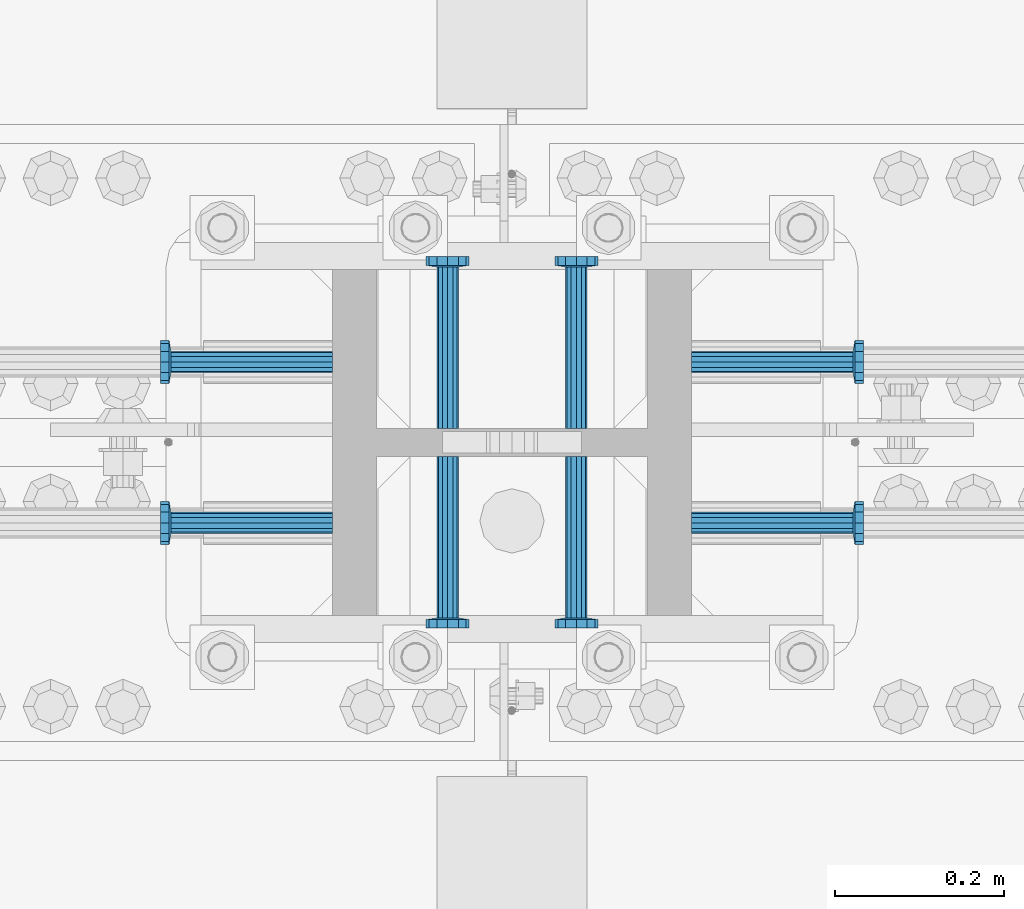
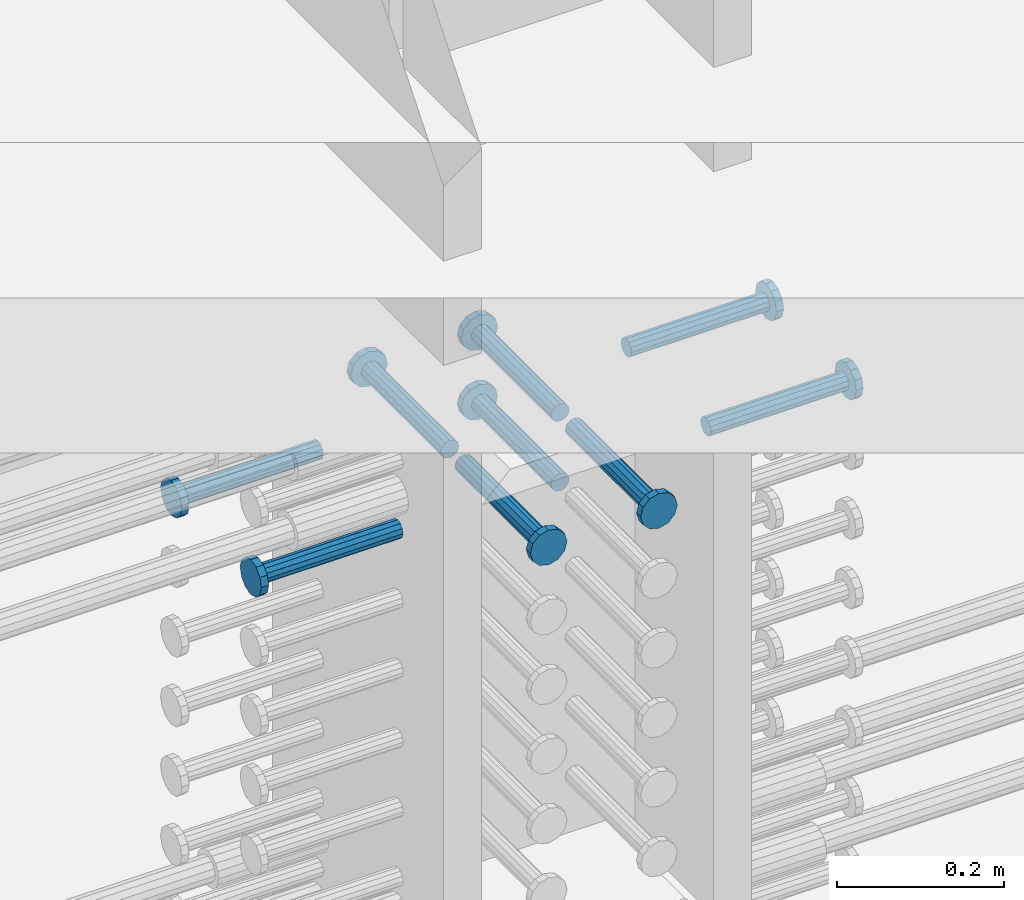
# One storey, part 1217 of 1763: 9 beams, 1 element without a shape of its own.
"""IFC2X3 building model written with IfcOpenShell, lengths in millimetres."""

from ifc_helpers import new_model, si_unit, frame, origin_with_axes, place, context, subcontext, project, spatial, faceted_brep, material, type_object, element, aggregate, save


model = new_model("IFC2X3")

# Units and contexts
model_context = context("Model", 3, precision=1e-05, world=origin_with_axes())
body_context = subcontext(model_context, "Body", "Model", "MODEL_VIEW")
ifc_project = project(units=[si_unit("LENGTHUNIT", "METRE", prefix="MILLI"), si_unit("AREAUNIT", "SQUARE_METRE"), si_unit("VOLUMEUNIT", "CUBIC_METRE"), si_unit("MASSUNIT", "GRAM", prefix="KILO"), si_unit("TIMEUNIT", "SECOND"), si_unit("PLANEANGLEUNIT", "RADIAN"), si_unit("SOLIDANGLEUNIT", "STERADIAN"), si_unit("THERMODYNAMICTEMPERATUREUNIT", "DEGREE_CELSIUS"), si_unit("LUMINOUSINTENSITYUNIT", "LUMEN")], contexts=[model_context])

# Site, building, storey
site_placement = place(None, origin_with_axes())
site = spatial("IfcSite", under=ifc_project, at=site_placement, CompositionType="ELEMENT")
building_placement = place(site_placement, origin_with_axes())
building = spatial("IfcBuilding", under=site, at=building_placement, Name="Undefined", CompositionType="ELEMENT")
storey_placement = place(building_placement, origin_with_axes())
storey = spatial("IfcBuildingStorey", under=building, at=storey_placement, Name="Undefined", CompositionType="ELEMENT", Elevation=0.0)

# Assembly, beams
assembly_placement = place(storey_placement, origin_with_axes())
assembly = element("IfcElementAssembly", 1, at=assembly_placement, inside=storey, Name="COLUMN", AssemblyPlace="NOTDEFINED", PredefinedType="RIGID_FRAME")
ifc_material = material(Name="STEEL/A108")
beam_type = type_object("IfcBeamType", PredefinedType="NOTDEFINED")
beam_1_placement = place(assembly_placement, frame((-61518.2373431004, 473.869000000006, 4724.40000000007), z_axis=(1.0, 0.0, 0.0), x_axis=(0.0, 1.0, 0.0)))
beam_1 = element("IfcBeam", 2, at=beam_1_placement, type_object=beam_type, material=ifc_material, Name="HEADED STUD ANCHOR", context=body_context, shape_type="Brep", body=[
    faceted_brep([(0.0, -12.6999999999971, -1.81898940354586e-12), (3.63797880709171e-12, -11.0, -6.34999990463257), (191.00799999576, -11.0, -6.34999990454889), (191.007999995752, -12.6999998092651, 8.36735125631094e-11), (7.27595761418343e-12, -6.34999990463257, -11.0), (191.00799999576, -6.34999990463257, -10.9999999999163), (3.63797880709171e-12, 0.0, -12.6999998092651), (191.00799999576, 0.0, -12.6999998091815), (7.27595761418343e-12, 6.34999990463257, -11.0), (191.00799999576, 6.34999990463257, -10.9999999999163), (3.63797880709171e-12, 11.0, -6.34999990463257), (191.00799999576, 11.0, -6.34999990454889), (0.0, 12.6999999999971, -1.81898940354586e-12), (191.007999995752, 12.6999998092651, 8.36735125631094e-11), (0.0, 11.0, 6.34999990463257), (191.007999995752, 11.0, 6.34999990471624), (-3.63797880709171e-12, 6.34999990463257, 11.0), (191.007999995749, 6.34999990463257, 11.0000000000837), (-3.63797880709171e-12, 0.0, 12.6999998092651), (191.007999995749, 0.0, 12.6999998093488), (-3.63797880709171e-12, -6.34999990463257, 11.0), (191.007999995749, -6.34999990463257, 11.0000000000837), (0.0, -11.0, 6.34999990463257), (191.007999995752, -11.0, 6.34999990471624), (193.039999995715, -22.0, -12.6999998091796), (193.039999995708, -25.3999996185303, 8.54925019666553e-11), (193.039999995719, -12.6999998092651, -21.9999999999145), (193.039999995719, 0.0, -25.3999996184448), (193.039999995719, 12.6999998092651, -21.9999999999145), (193.039999995715, 22.0, -12.6999998091796), (193.039999995708, 25.3999996185303, 8.54925019666553e-11), (193.039999995704, 22.0, 12.6999998093506), (193.039999995701, 12.6999998092651, 22.0000000000855), (193.039999995697, 0.0, 25.3999996186158), (193.039999995701, -12.6999998092651, 22.0000000000855), (193.039999995704, -22.0, 12.6999998093506), (203.199999995486, -22.0, -12.6999998091742), (203.199999995482, -25.3999996185303, 9.09494701772928e-11), (203.199999995493, -12.6999998092651, -21.9999999999091), (203.199999995493, 0.0, -25.3999996184393), (203.199999995493, 12.6999998092651, -21.9999999999091), (203.199999995486, 22.0, -12.6999998091742), (203.199999995482, 25.3999996185303, 9.09494701772928e-11), (203.199999995479, 22.0, 12.6999998093561), (203.199999995475, 12.6999998092651, 22.0000000000909), (203.199999995471, 0.0, 25.3999996186212), (203.199999995475, -12.6999998092651, 22.0000000000909), (203.199999995479, -22.0, 12.6999998093561)], [[[0, 1, 2, 3]], [[1, 4, 5, 2]], [[4, 6, 7, 5]], [[6, 8, 9, 7]], [[8, 10, 11, 9]], [[10, 12, 13, 11]], [[12, 14, 15, 13]], [[14, 16, 17, 15]], [[16, 18, 19, 17]], [[18, 20, 21, 19]], [[20, 22, 23, 21]], [[22, 0, 3, 23]], [[22, 20, 18, 16, 14, 12, 10, 8, 6, 4, 1, 0]], [[3, 2, 24, 25]], [[2, 5, 26, 24]], [[5, 7, 27, 26]], [[7, 9, 28, 27]], [[9, 11, 29, 28]], [[11, 13, 30, 29]], [[13, 15, 31, 30]], [[15, 17, 32, 31]], [[17, 19, 33, 32]], [[19, 21, 34, 33]], [[21, 23, 35, 34]], [[23, 3, 25, 35]], [[25, 24, 36, 37]], [[24, 26, 38, 36]], [[26, 27, 39, 38]], [[27, 28, 40, 39]], [[28, 29, 41, 40]], [[29, 30, 42, 41]], [[30, 31, 43, 42]], [[31, 32, 44, 43]], [[32, 33, 45, 44]], [[33, 34, 46, 45]], [[34, 35, 47, 46]], [[35, 25, 37, 47]], [[38, 39, 40, 41, 42, 43, 44, 45, 46, 47, 37, 36]]]),
])
beam_2_placement = place(assembly_placement, frame((-61670.6373431002, 473.868999002865, 4724.40000000007), z_axis=(1.0, 0.0, 0.0), x_axis=(0.0, 1.0, 0.0)))
beam_2 = element("IfcBeam", 3, at=beam_2_placement, type_object=beam_type, material=ifc_material, Name="HEADED STUD ANCHOR", context=body_context, shape_type="Brep", body=[
    faceted_brep([(0.0, -12.6999999999971, -1.81898940354586e-12), (3.63797880709171e-12, -11.0, -6.34999990463257), (191.00799999576, -11.0, -6.34999990454889), (191.007999995752, -12.6999998092651, 8.36735125631094e-11), (7.27595761418343e-12, -6.34999990463257, -11.0), (191.00799999576, -6.34999990463257, -10.9999999999163), (3.63797880709171e-12, 0.0, -12.6999998092651), (191.00799999576, 0.0, -12.6999998091815), (7.27595761418343e-12, 6.34999990463257, -11.0), (191.00799999576, 6.34999990463257, -10.9999999999163), (3.63797880709171e-12, 11.0, -6.34999990463257), (191.00799999576, 11.0, -6.34999990454889), (0.0, 12.6999999999971, -1.81898940354586e-12), (191.007999995752, 12.6999998092651, 8.36735125631094e-11), (0.0, 11.0, 6.34999990463257), (191.007999995752, 11.0, 6.34999990471624), (-3.63797880709171e-12, 6.34999990463257, 11.0), (191.007999995749, 6.34999990463257, 11.0000000000837), (-3.63797880709171e-12, 0.0, 12.6999998092651), (191.007999995749, 0.0, 12.6999998093488), (-3.63797880709171e-12, -6.34999990463257, 11.0), (191.007999995749, -6.34999990463257, 11.0000000000837), (0.0, -11.0, 6.34999990463257), (191.007999995752, -11.0, 6.34999990471624), (193.039999995715, -22.0, -12.6999998091796), (193.039999995708, -25.3999996185303, 8.54925019666553e-11), (193.039999995719, -12.6999998092651, -21.9999999999145), (193.039999995719, 0.0, -25.3999996184448), (193.039999995719, 12.6999998092651, -21.9999999999145), (193.039999995715, 22.0, -12.6999998091796), (193.039999995708, 25.3999996185303, 8.54925019666553e-11), (193.039999995704, 22.0, 12.6999998093506), (193.039999995701, 12.6999998092651, 22.0000000000855), (193.039999995697, 0.0, 25.3999996186158), (193.039999995701, -12.6999998092651, 22.0000000000855), (193.039999995704, -22.0, 12.6999998093506), (203.199999995486, -22.0, -12.6999998091742), (203.199999995482, -25.3999996185303, 9.09494701772928e-11), (203.199999995493, -12.6999998092651, -21.9999999999091), (203.199999995493, 0.0, -25.3999996184393), (203.199999995493, 12.6999998092651, -21.9999999999091), (203.199999995486, 22.0, -12.6999998091742), (203.199999995482, 25.3999996185303, 9.09494701772928e-11), (203.199999995479, 22.0, 12.6999998093561), (203.199999995475, 12.6999998092651, 22.0000000000909), (203.199999995471, 0.0, 25.3999996186212), (203.199999995475, -12.6999998092651, 22.0000000000909), (203.199999995479, -22.0, 12.6999998093561)], [[[0, 1, 2, 3]], [[1, 4, 5, 2]], [[4, 6, 7, 5]], [[6, 8, 9, 7]], [[8, 10, 11, 9]], [[10, 12, 13, 11]], [[12, 14, 15, 13]], [[14, 16, 17, 15]], [[16, 18, 19, 17]], [[18, 20, 21, 19]], [[20, 22, 23, 21]], [[22, 0, 3, 23]], [[22, 20, 18, 16, 14, 12, 10, 8, 6, 4, 1, 0]], [[3, 2, 24, 25]], [[2, 5, 26, 24]], [[5, 7, 27, 26]], [[7, 9, 28, 27]], [[9, 11, 29, 28]], [[11, 13, 30, 29]], [[13, 15, 31, 30]], [[15, 17, 32, 31]], [[17, 19, 33, 32]], [[19, 21, 34, 33]], [[21, 23, 35, 34]], [[23, 3, 25, 35]], [[25, 24, 36, 37]], [[24, 26, 38, 36]], [[26, 27, 39, 38]], [[27, 28, 40, 39]], [[28, 29, 41, 40]], [[29, 30, 42, 41]], [[30, 31, 43, 42]], [[31, 32, 44, 43]], [[32, 33, 45, 44]], [[33, 34, 46, 45]], [[34, 35, 47, 46]], [[35, 25, 37, 47]], [[38, 39, 40, 41, 42, 43, 44, 45, 46, 47, 37, 36]]]),
])
beam_3_placement = place(assembly_placement, frame((-61807.1622049631, 552.449999999823, 4724.40000000007), z_axis=(0.0, 1.0, 0.0), x_axis=(-1.0, 0.0, 0.0)))
beam_3 = element("IfcBeam", 4, at=beam_3_placement, type_object=beam_type, material=ifc_material, Name="HEADED STUD ANCHOR", context=body_context, shape_type="Brep", body=[
    faceted_brep([(0.0, -12.6999999999971, -1.81898940354586e-12), (3.63797880709171e-12, -11.0, -6.34999990463257), (191.00799999576, -11.0, -6.34999990454889), (191.007999995752, -12.6999998092651, 8.36735125631094e-11), (7.27595761418343e-12, -6.34999990463257, -11.0), (191.00799999576, -6.34999990463257, -10.9999999999163), (3.63797880709171e-12, 0.0, -12.6999998092651), (191.00799999576, 0.0, -12.6999998091815), (7.27595761418343e-12, 6.34999990463257, -11.0), (191.00799999576, 6.34999990463257, -10.9999999999163), (3.63797880709171e-12, 11.0, -6.34999990463257), (191.00799999576, 11.0, -6.34999990454889), (0.0, 12.6999999999971, -1.81898940354586e-12), (191.007999995752, 12.6999998092651, 8.36735125631094e-11), (0.0, 11.0, 6.34999990463257), (191.007999995752, 11.0, 6.34999990471624), (-3.63797880709171e-12, 6.34999990463257, 11.0), (191.007999995749, 6.34999990463257, 11.0000000000837), (-3.63797880709171e-12, 0.0, 12.6999998092651), (191.007999995749, 0.0, 12.6999998093488), (-3.63797880709171e-12, -6.34999990463257, 11.0), (191.007999995749, -6.34999990463257, 11.0000000000837), (0.0, -11.0, 6.34999990463257), (191.007999995752, -11.0, 6.34999990471624), (193.039999995715, -22.0, -12.6999998091796), (193.039999995708, -25.3999996185303, 8.54925019666553e-11), (193.039999995719, -12.6999998092651, -21.9999999999145), (193.039999995719, 0.0, -25.3999996184448), (193.039999995719, 12.6999998092651, -21.9999999999145), (193.039999995715, 22.0, -12.6999998091796), (193.039999995708, 25.3999996185303, 8.54925019666553e-11), (193.039999995704, 22.0, 12.6999998093506), (193.039999995701, 12.6999998092651, 22.0000000000855), (193.039999995697, 0.0, 25.3999996186158), (193.039999995701, -12.6999998092651, 22.0000000000855), (193.039999995704, -22.0, 12.6999998093506), (203.199999995486, -22.0, -12.6999998091742), (203.199999995482, -25.3999996185303, 9.09494701772928e-11), (203.199999995493, -12.6999998092651, -21.9999999999091), (203.199999995493, 0.0, -25.3999996184393), (203.199999995493, 12.6999998092651, -21.9999999999091), (203.199999995486, 22.0, -12.6999998091742), (203.199999995482, 25.3999996185303, 9.09494701772928e-11), (203.199999995479, 22.0, 12.6999998093561), (203.199999995475, 12.6999998092651, 22.0000000000909), (203.199999995471, 0.0, 25.3999996186212), (203.199999995475, -12.6999998092651, 22.0000000000909), (203.199999995479, -22.0, 12.6999998093561)], [[[0, 1, 2, 3]], [[1, 4, 5, 2]], [[4, 6, 7, 5]], [[6, 8, 9, 7]], [[8, 10, 11, 9]], [[10, 12, 13, 11]], [[12, 14, 15, 13]], [[14, 16, 17, 15]], [[16, 18, 19, 17]], [[18, 20, 21, 19]], [[20, 22, 23, 21]], [[22, 0, 3, 23]], [[22, 20, 18, 16, 14, 12, 10, 8, 6, 4, 1, 0]], [[3, 2, 24, 25]], [[2, 5, 26, 24]], [[5, 7, 27, 26]], [[7, 9, 28, 27]], [[9, 11, 29, 28]], [[11, 13, 30, 29]], [[13, 15, 31, 30]], [[15, 17, 32, 31]], [[17, 19, 33, 32]], [[19, 21, 34, 33]], [[21, 23, 35, 34]], [[23, 3, 25, 35]], [[25, 24, 36, 37]], [[24, 26, 38, 36]], [[26, 27, 39, 38]], [[27, 28, 40, 39]], [[28, 29, 41, 40]], [[29, 30, 42, 41]], [[30, 31, 43, 42]], [[31, 32, 44, 43]], [[32, 33, 45, 44]], [[33, 34, 46, 45]], [[34, 35, 47, 46]], [[35, 25, 37, 47]], [[38, 39, 40, 41, 42, 43, 44, 45, 46, 47, 37, 36]]]),
])
beam_4_placement = place(assembly_placement, frame((-61807.1622736986, 361.949999999998, 4724.40000000007), z_axis=(0.0, 1.0, 0.0), x_axis=(-1.0, 0.0, 0.0)))
beam_4 = element("IfcBeam", 5, at=beam_4_placement, type_object=beam_type, material=ifc_material, Name="HEADED STUD ANCHOR", context=body_context, shape_type="Brep", body=[
    faceted_brep([(0.0, -12.6999999999971, -1.81898940354586e-12), (3.63797880709171e-12, -11.0, -6.34999990463257), (191.00799999576, -11.0, -6.34999990454889), (191.007999995752, -12.6999998092651, 8.36735125631094e-11), (7.27595761418343e-12, -6.34999990463257, -11.0), (191.00799999576, -6.34999990463257, -10.9999999999163), (3.63797880709171e-12, 0.0, -12.6999998092651), (191.00799999576, 0.0, -12.6999998091815), (7.27595761418343e-12, 6.34999990463257, -11.0), (191.00799999576, 6.34999990463257, -10.9999999999163), (3.63797880709171e-12, 11.0, -6.34999990463257), (191.00799999576, 11.0, -6.34999990454889), (0.0, 12.6999999999971, -1.81898940354586e-12), (191.007999995752, 12.6999998092651, 8.36735125631094e-11), (0.0, 11.0, 6.34999990463257), (191.007999995752, 11.0, 6.34999990471624), (-3.63797880709171e-12, 6.34999990463257, 11.0), (191.007999995749, 6.34999990463257, 11.0000000000837), (-3.63797880709171e-12, 0.0, 12.6999998092651), (191.007999995749, 0.0, 12.6999998093488), (-3.63797880709171e-12, -6.34999990463257, 11.0), (191.007999995749, -6.34999990463257, 11.0000000000837), (0.0, -11.0, 6.34999990463257), (191.007999995752, -11.0, 6.34999990471624), (193.039999995715, -22.0, -12.6999998091796), (193.039999995708, -25.3999996185303, 8.54925019666553e-11), (193.039999995719, -12.6999998092651, -21.9999999999145), (193.039999995719, 0.0, -25.3999996184448), (193.039999995719, 12.6999998092651, -21.9999999999145), (193.039999995715, 22.0, -12.6999998091796), (193.039999995708, 25.3999996185303, 8.54925019666553e-11), (193.039999995704, 22.0, 12.6999998093506), (193.039999995701, 12.6999998092651, 22.0000000000855), (193.039999995697, 0.0, 25.3999996186158), (193.039999995701, -12.6999998092651, 22.0000000000855), (193.039999995704, -22.0, 12.6999998093506), (203.199999995486, -22.0, -12.6999998091742), (203.199999995482, -25.3999996185303, 9.09494701772928e-11), (203.199999995493, -12.6999998092651, -21.9999999999091), (203.199999995493, 0.0, -25.3999996184393), (203.199999995493, 12.6999998092651, -21.9999999999091), (203.199999995486, 22.0, -12.6999998091742), (203.199999995482, 25.3999996185303, 9.09494701772928e-11), (203.199999995479, 22.0, 12.6999998093561), (203.199999995475, 12.6999998092651, 22.0000000000909), (203.199999995471, 0.0, 25.3999996186212), (203.199999995475, -12.6999998092651, 22.0000000000909), (203.199999995479, -22.0, 12.6999998093561)], [[[0, 1, 2, 3]], [[1, 4, 5, 2]], [[4, 6, 7, 5]], [[6, 8, 9, 7]], [[8, 10, 11, 9]], [[10, 12, 13, 11]], [[12, 14, 15, 13]], [[14, 16, 17, 15]], [[16, 18, 19, 17]], [[18, 20, 21, 19]], [[20, 22, 23, 21]], [[22, 0, 3, 23]], [[22, 20, 18, 16, 14, 12, 10, 8, 6, 4, 1, 0]], [[3, 2, 24, 25]], [[2, 5, 26, 24]], [[5, 7, 27, 26]], [[7, 9, 28, 27]], [[9, 11, 29, 28]], [[11, 13, 30, 29]], [[13, 15, 31, 30]], [[15, 17, 32, 31]], [[17, 19, 33, 32]], [[19, 21, 34, 33]], [[21, 23, 35, 34]], [[23, 3, 25, 35]], [[25, 24, 36, 37]], [[24, 26, 38, 36]], [[26, 27, 39, 38]], [[27, 28, 40, 39]], [[28, 29, 41, 40]], [[29, 30, 42, 41]], [[30, 31, 43, 42]], [[31, 32, 44, 43]], [[32, 33, 45, 44]], [[33, 34, 46, 45]], [[34, 35, 47, 46]], [[35, 25, 37, 47]], [[38, 39, 40, 41, 42, 43, 44, 45, 46, 47, 37, 36]]]),
])
beam_5_placement = place(assembly_placement, frame((-61670.6373420916, 440.53099988573, 4724.40000000007), z_axis=(1.0, 0.0, 0.0), x_axis=(0.0, -1.0, 0.0)))
beam_5 = element("IfcBeam", 6, at=beam_5_placement, type_object=beam_type, material=ifc_material, Name="HEADED STUD ANCHOR", context=body_context, shape_type="Brep", body=[
    faceted_brep([(0.0, -12.6999999999971, -1.81898940354586e-12), (3.63797880709171e-12, -11.0, -6.34999990463257), (191.00799999576, -11.0, -6.34999990454889), (191.007999995752, -12.6999998092651, 8.36735125631094e-11), (7.27595761418343e-12, -6.34999990463257, -11.0), (191.00799999576, -6.34999990463257, -10.9999999999163), (3.63797880709171e-12, 0.0, -12.6999998092651), (191.00799999576, 0.0, -12.6999998091815), (7.27595761418343e-12, 6.34999990463257, -11.0), (191.00799999576, 6.34999990463257, -10.9999999999163), (3.63797880709171e-12, 11.0, -6.34999990463257), (191.00799999576, 11.0, -6.34999990454889), (0.0, 12.6999999999971, -1.81898940354586e-12), (191.007999995752, 12.6999998092651, 8.36735125631094e-11), (0.0, 11.0, 6.34999990463257), (191.007999995752, 11.0, 6.34999990471624), (-3.63797880709171e-12, 6.34999990463257, 11.0), (191.007999995749, 6.34999990463257, 11.0000000000837), (-3.63797880709171e-12, 0.0, 12.6999998092651), (191.007999995749, 0.0, 12.6999998093488), (-3.63797880709171e-12, -6.34999990463257, 11.0), (191.007999995749, -6.34999990463257, 11.0000000000837), (0.0, -11.0, 6.34999990463257), (191.007999995752, -11.0, 6.34999990471624), (193.039999995715, -22.0, -12.6999998091796), (193.039999995708, -25.3999996185303, 8.54925019666553e-11), (193.039999995719, -12.6999998092651, -21.9999999999145), (193.039999995719, 0.0, -25.3999996184448), (193.039999995719, 12.6999998092651, -21.9999999999145), (193.039999995715, 22.0, -12.6999998091796), (193.039999995708, 25.3999996185303, 8.54925019666553e-11), (193.039999995704, 22.0, 12.6999998093506), (193.039999995701, 12.6999998092651, 22.0000000000855), (193.039999995697, 0.0, 25.3999996186158), (193.039999995701, -12.6999998092651, 22.0000000000855), (193.039999995704, -22.0, 12.6999998093506), (203.199999995486, -22.0, -12.6999998091742), (203.199999995482, -25.3999996185303, 9.09494701772928e-11), (203.199999995493, -12.6999998092651, -21.9999999999091), (203.199999995493, 0.0, -25.3999996184393), (203.199999995493, 12.6999998092651, -21.9999999999091), (203.199999995486, 22.0, -12.6999998091742), (203.199999995482, 25.3999996185303, 9.09494701772928e-11), (203.199999995479, 22.0, 12.6999998093561), (203.199999995475, 12.6999998092651, 22.0000000000909), (203.199999995471, 0.0, 25.3999996186212), (203.199999995475, -12.6999998092651, 22.0000000000909), (203.199999995479, -22.0, 12.6999998093561)], [[[0, 1, 2, 3]], [[1, 4, 5, 2]], [[4, 6, 7, 5]], [[6, 8, 9, 7]], [[8, 10, 11, 9]], [[10, 12, 13, 11]], [[12, 14, 15, 13]], [[14, 16, 17, 15]], [[16, 18, 19, 17]], [[18, 20, 21, 19]], [[20, 22, 23, 21]], [[22, 0, 3, 23]], [[22, 20, 18, 16, 14, 12, 10, 8, 6, 4, 1, 0]], [[3, 2, 24, 25]], [[2, 5, 26, 24]], [[5, 7, 27, 26]], [[7, 9, 28, 27]], [[9, 11, 29, 28]], [[11, 13, 30, 29]], [[13, 15, 31, 30]], [[15, 17, 32, 31]], [[17, 19, 33, 32]], [[19, 21, 34, 33]], [[21, 23, 35, 34]], [[23, 3, 25, 35]], [[25, 24, 36, 37]], [[24, 26, 38, 36]], [[26, 27, 39, 38]], [[27, 28, 40, 39]], [[28, 29, 41, 40]], [[29, 30, 42, 41]], [[30, 31, 43, 42]], [[31, 32, 44, 43]], [[32, 33, 45, 44]], [[33, 34, 46, 45]], [[34, 35, 47, 46]], [[35, 25, 37, 47]], [[38, 39, 40, 41, 42, 43, 44, 45, 46, 47, 37, 36]]]),
])
beam_6_placement = place(assembly_placement, frame((-61518.2373420926, 440.531000000006, 4724.40000000007), z_axis=(1.0, 0.0, 0.0), x_axis=(0.0, -1.0, 0.0)))
beam_6 = element("IfcBeam", 7, at=beam_6_placement, type_object=beam_type, material=ifc_material, Name="HEADED STUD ANCHOR", context=body_context, shape_type="Brep", body=[
    faceted_brep([(0.0, -12.6999999999971, -1.81898940354586e-12), (3.63797880709171e-12, -11.0, -6.34999990463257), (191.00799999576, -11.0, -6.34999990454889), (191.007999995752, -12.6999998092651, 8.36735125631094e-11), (7.27595761418343e-12, -6.34999990463257, -11.0), (191.00799999576, -6.34999990463257, -10.9999999999163), (3.63797880709171e-12, 0.0, -12.6999998092651), (191.00799999576, 0.0, -12.6999998091815), (7.27595761418343e-12, 6.34999990463257, -11.0), (191.00799999576, 6.34999990463257, -10.9999999999163), (3.63797880709171e-12, 11.0, -6.34999990463257), (191.00799999576, 11.0, -6.34999990454889), (0.0, 12.6999999999971, -1.81898940354586e-12), (191.007999995752, 12.6999998092651, 8.36735125631094e-11), (0.0, 11.0, 6.34999990463257), (191.007999995752, 11.0, 6.34999990471624), (-3.63797880709171e-12, 6.34999990463257, 11.0), (191.007999995749, 6.34999990463257, 11.0000000000837), (-3.63797880709171e-12, 0.0, 12.6999998092651), (191.007999995749, 0.0, 12.6999998093488), (-3.63797880709171e-12, -6.34999990463257, 11.0), (191.007999995749, -6.34999990463257, 11.0000000000837), (0.0, -11.0, 6.34999990463257), (191.007999995752, -11.0, 6.34999990471624), (193.039999995715, -22.0, -12.6999998091796), (193.039999995708, -25.3999996185303, 8.54925019666553e-11), (193.039999995719, -12.6999998092651, -21.9999999999145), (193.039999995719, 0.0, -25.3999996184448), (193.039999995719, 12.6999998092651, -21.9999999999145), (193.039999995715, 22.0, -12.6999998091796), (193.039999995708, 25.3999996185303, 8.54925019666553e-11), (193.039999995704, 22.0, 12.6999998093506), (193.039999995701, 12.6999998092651, 22.0000000000855), (193.039999995697, 0.0, 25.3999996186158), (193.039999995701, -12.6999998092651, 22.0000000000855), (193.039999995704, -22.0, 12.6999998093506), (203.199999995486, -22.0, -12.6999998091742), (203.199999995482, -25.3999996185303, 9.09494701772928e-11), (203.199999995493, -12.6999998092651, -21.9999999999091), (203.199999995493, 0.0, -25.3999996184393), (203.199999995493, 12.6999998092651, -21.9999999999091), (203.199999995486, 22.0, -12.6999998091742), (203.199999995482, 25.3999996185303, 9.09494701772928e-11), (203.199999995479, 22.0, 12.6999998093561), (203.199999995475, 12.6999998092651, 22.0000000000909), (203.199999995471, 0.0, 25.3999996186212), (203.199999995475, -12.6999998092651, 22.0000000000909), (203.199999995479, -22.0, 12.6999998093561)], [[[0, 1, 2, 3]], [[1, 4, 5, 2]], [[4, 6, 7, 5]], [[6, 8, 9, 7]], [[8, 10, 11, 9]], [[10, 12, 13, 11]], [[12, 14, 15, 13]], [[14, 16, 17, 15]], [[16, 18, 19, 17]], [[18, 20, 21, 19]], [[20, 22, 23, 21]], [[22, 0, 3, 23]], [[22, 20, 18, 16, 14, 12, 10, 8, 6, 4, 1, 0]], [[3, 2, 24, 25]], [[2, 5, 26, 24]], [[5, 7, 27, 26]], [[7, 9, 28, 27]], [[9, 11, 29, 28]], [[11, 13, 30, 29]], [[13, 15, 31, 30]], [[15, 17, 32, 31]], [[17, 19, 33, 32]], [[19, 21, 34, 33]], [[21, 23, 35, 34]], [[23, 3, 25, 35]], [[25, 24, 36, 37]], [[24, 26, 38, 36]], [[26, 27, 39, 38]], [[27, 28, 40, 39]], [[28, 29, 41, 40]], [[29, 30, 42, 41]], [[30, 31, 43, 42]], [[31, 32, 44, 43]], [[32, 33, 45, 44]], [[33, 34, 46, 45]], [[34, 35, 47, 46]], [[35, 25, 37, 47]], [[38, 39, 40, 41, 42, 43, 44, 45, 46, 47, 37, 36]]]),
])
beam_7_placement = place(assembly_placement, frame((-61381.7123210203, 361.950000000609, 4724.40000000007), z_axis=(0.0, 1.0, 0.0), x_axis=(1.0, 0.0, 0.0)))
beam_7 = element("IfcBeam", 8, at=beam_7_placement, type_object=beam_type, material=ifc_material, Name="HEADED STUD ANCHOR", context=body_context, shape_type="Brep", body=[
    faceted_brep([(0.0, -12.6999999999971, -1.81898940354586e-12), (3.63797880709171e-12, -11.0, -6.34999990463257), (191.00799999576, -11.0, -6.34999990454889), (191.007999995752, -12.6999998092651, 8.36735125631094e-11), (7.27595761418343e-12, -6.34999990463257, -11.0), (191.00799999576, -6.34999990463257, -10.9999999999163), (3.63797880709171e-12, 0.0, -12.6999998092651), (191.00799999576, 0.0, -12.6999998091815), (7.27595761418343e-12, 6.34999990463257, -11.0), (191.00799999576, 6.34999990463257, -10.9999999999163), (3.63797880709171e-12, 11.0, -6.34999990463257), (191.00799999576, 11.0, -6.34999990454889), (0.0, 12.6999999999971, -1.81898940354586e-12), (191.007999995752, 12.6999998092651, 8.36735125631094e-11), (0.0, 11.0, 6.34999990463257), (191.007999995752, 11.0, 6.34999990471624), (-3.63797880709171e-12, 6.34999990463257, 11.0), (191.007999995749, 6.34999990463257, 11.0000000000837), (-3.63797880709171e-12, 0.0, 12.6999998092651), (191.007999995749, 0.0, 12.6999998093488), (-3.63797880709171e-12, -6.34999990463257, 11.0), (191.007999995749, -6.34999990463257, 11.0000000000837), (0.0, -11.0, 6.34999990463257), (191.007999995752, -11.0, 6.34999990471624), (193.039999995715, -22.0, -12.6999998091796), (193.039999995708, -25.3999996185303, 8.54925019666553e-11), (193.039999995719, -12.6999998092651, -21.9999999999145), (193.039999995719, 0.0, -25.3999996184448), (193.039999995719, 12.6999998092651, -21.9999999999145), (193.039999995715, 22.0, -12.6999998091796), (193.039999995708, 25.3999996185303, 8.54925019666553e-11), (193.039999995704, 22.0, 12.6999998093506), (193.039999995701, 12.6999998092651, 22.0000000000855), (193.039999995697, 0.0, 25.3999996186158), (193.039999995701, -12.6999998092651, 22.0000000000855), (193.039999995704, -22.0, 12.6999998093506), (203.199999995486, -22.0, -12.6999998091742), (203.199999995482, -25.3999996185303, 9.09494701772928e-11), (203.199999995493, -12.6999998092651, -21.9999999999091), (203.199999995493, 0.0, -25.3999996184393), (203.199999995493, 12.6999998092651, -21.9999999999091), (203.199999995486, 22.0, -12.6999998091742), (203.199999995482, 25.3999996185303, 9.09494701772928e-11), (203.199999995479, 22.0, 12.6999998093561), (203.199999995475, 12.6999998092651, 22.0000000000909), (203.199999995471, 0.0, 25.3999996186212), (203.199999995475, -12.6999998092651, 22.0000000000909), (203.199999995479, -22.0, 12.6999998093561)], [[[0, 1, 2, 3]], [[1, 4, 5, 2]], [[4, 6, 7, 5]], [[6, 8, 9, 7]], [[8, 10, 11, 9]], [[10, 12, 13, 11]], [[12, 14, 15, 13]], [[14, 16, 17, 15]], [[16, 18, 19, 17]], [[18, 20, 21, 19]], [[20, 22, 23, 21]], [[22, 0, 3, 23]], [[22, 20, 18, 16, 14, 12, 10, 8, 6, 4, 1, 0]], [[3, 2, 24, 25]], [[2, 5, 26, 24]], [[5, 7, 27, 26]], [[7, 9, 28, 27]], [[9, 11, 29, 28]], [[11, 13, 30, 29]], [[13, 15, 31, 30]], [[15, 17, 32, 31]], [[17, 19, 33, 32]], [[19, 21, 34, 33]], [[21, 23, 35, 34]], [[23, 3, 25, 35]], [[25, 24, 36, 37]], [[24, 26, 38, 36]], [[26, 27, 39, 38]], [[27, 28, 40, 39]], [[28, 29, 41, 40]], [[29, 30, 42, 41]], [[30, 31, 43, 42]], [[31, 32, 44, 43]], [[32, 33, 45, 44]], [[33, 34, 46, 45]], [[34, 35, 47, 46]], [[35, 25, 37, 47]], [[38, 39, 40, 41, 42, 43, 44, 45, 46, 47, 37, 36]]]),
])
beam_8_placement = place(assembly_placement, frame((-61381.7122523598, 552.449999999998, 4724.40000000007), z_axis=(0.0, 1.0, 0.0), x_axis=(1.0, 0.0, 0.0)))
beam_8 = element("IfcBeam", 9, at=beam_8_placement, type_object=beam_type, material=ifc_material, Name="HEADED STUD ANCHOR", context=body_context, shape_type="Brep", body=[
    faceted_brep([(0.0, -12.6999999999971, -1.81898940354586e-12), (3.63797880709171e-12, -11.0, -6.34999990463257), (191.00799999576, -11.0, -6.34999990454889), (191.007999995752, -12.6999998092651, 8.36735125631094e-11), (7.27595761418343e-12, -6.34999990463257, -11.0), (191.00799999576, -6.34999990463257, -10.9999999999163), (3.63797880709171e-12, 0.0, -12.6999998092651), (191.00799999576, 0.0, -12.6999998091815), (7.27595761418343e-12, 6.34999990463257, -11.0), (191.00799999576, 6.34999990463257, -10.9999999999163), (3.63797880709171e-12, 11.0, -6.34999990463257), (191.00799999576, 11.0, -6.34999990454889), (0.0, 12.6999999999971, -1.81898940354586e-12), (191.007999995752, 12.6999998092651, 8.36735125631094e-11), (0.0, 11.0, 6.34999990463257), (191.007999995752, 11.0, 6.34999990471624), (-3.63797880709171e-12, 6.34999990463257, 11.0), (191.007999995749, 6.34999990463257, 11.0000000000837), (-3.63797880709171e-12, 0.0, 12.6999998092651), (191.007999995749, 0.0, 12.6999998093488), (-3.63797880709171e-12, -6.34999990463257, 11.0), (191.007999995749, -6.34999990463257, 11.0000000000837), (0.0, -11.0, 6.34999990463257), (191.007999995752, -11.0, 6.34999990471624), (193.039999995715, -22.0, -12.6999998091796), (193.039999995708, -25.3999996185303, 8.54925019666553e-11), (193.039999995719, -12.6999998092651, -21.9999999999145), (193.039999995719, 0.0, -25.3999996184448), (193.039999995719, 12.6999998092651, -21.9999999999145), (193.039999995715, 22.0, -12.6999998091796), (193.039999995708, 25.3999996185303, 8.54925019666553e-11), (193.039999995704, 22.0, 12.6999998093506), (193.039999995701, 12.6999998092651, 22.0000000000855), (193.039999995697, 0.0, 25.3999996186158), (193.039999995701, -12.6999998092651, 22.0000000000855), (193.039999995704, -22.0, 12.6999998093506), (203.199999995486, -22.0, -12.6999998091742), (203.199999995482, -25.3999996185303, 9.09494701772928e-11), (203.199999995493, -12.6999998092651, -21.9999999999091), (203.199999995493, 0.0, -25.3999996184393), (203.199999995493, 12.6999998092651, -21.9999999999091), (203.199999995486, 22.0, -12.6999998091742), (203.199999995482, 25.3999996185303, 9.09494701772928e-11), (203.199999995479, 22.0, 12.6999998093561), (203.199999995475, 12.6999998092651, 22.0000000000909), (203.199999995471, 0.0, 25.3999996186212), (203.199999995475, -12.6999998092651, 22.0000000000909), (203.199999995479, -22.0, 12.6999998093561)], [[[0, 1, 2, 3]], [[1, 4, 5, 2]], [[4, 6, 7, 5]], [[6, 8, 9, 7]], [[8, 10, 11, 9]], [[10, 12, 13, 11]], [[12, 14, 15, 13]], [[14, 16, 17, 15]], [[16, 18, 19, 17]], [[18, 20, 21, 19]], [[20, 22, 23, 21]], [[22, 0, 3, 23]], [[22, 20, 18, 16, 14, 12, 10, 8, 6, 4, 1, 0]], [[3, 2, 24, 25]], [[2, 5, 26, 24]], [[5, 7, 27, 26]], [[7, 9, 28, 27]], [[9, 11, 29, 28]], [[11, 13, 30, 29]], [[13, 15, 31, 30]], [[15, 17, 32, 31]], [[17, 19, 33, 32]], [[19, 21, 34, 33]], [[21, 23, 35, 34]], [[23, 3, 25, 35]], [[25, 24, 36, 37]], [[24, 26, 38, 36]], [[26, 27, 39, 38]], [[27, 28, 40, 39]], [[28, 29, 41, 40]], [[29, 30, 42, 41]], [[30, 31, 43, 42]], [[31, 32, 44, 43]], [[32, 33, 45, 44]], [[33, 34, 46, 45]], [[34, 35, 47, 46]], [[35, 25, 37, 47]], [[38, 39, 40, 41, 42, 43, 44, 45, 46, 47, 37, 36]]]),
])
beam_9_placement = place(assembly_placement, frame((-61518.2373431004, 473.869000000006, 4622.80000000005), z_axis=(1.0, 0.0, 0.0), x_axis=(0.0, 1.0, 0.0)))
beam_9 = element("IfcBeam", 10, at=beam_9_placement, type_object=beam_type, material=ifc_material, Name="HEADED STUD ANCHOR", context=body_context, shape_type="Brep", body=[
    faceted_brep([(0.0, -12.6999999999971, -1.81898940354586e-12), (3.63797880709171e-12, -11.0, -6.34999990463257), (191.00799999576, -11.0, -6.34999990454889), (191.007999995752, -12.6999998092651, 8.36735125631094e-11), (7.27595761418343e-12, -6.34999990463257, -11.0), (191.00799999576, -6.34999990463257, -10.9999999999163), (3.63797880709171e-12, 0.0, -12.6999998092651), (191.00799999576, 0.0, -12.6999998091815), (7.27595761418343e-12, 6.34999990463257, -11.0), (191.00799999576, 6.34999990463257, -10.9999999999163), (3.63797880709171e-12, 11.0, -6.34999990463257), (191.00799999576, 11.0, -6.34999990454889), (0.0, 12.6999999999971, -1.81898940354586e-12), (191.007999995752, 12.6999998092651, 8.36735125631094e-11), (0.0, 11.0, 6.34999990463257), (191.007999995752, 11.0, 6.34999990471624), (-3.63797880709171e-12, 6.34999990463257, 11.0), (191.007999995749, 6.34999990463257, 11.0000000000837), (-3.63797880709171e-12, 0.0, 12.6999998092651), (191.007999995749, 0.0, 12.6999998093488), (-3.63797880709171e-12, -6.34999990463257, 11.0), (191.007999995749, -6.34999990463257, 11.0000000000837), (0.0, -11.0, 6.34999990463257), (191.007999995752, -11.0, 6.34999990471624), (193.039999995715, -22.0, -12.6999998091796), (193.039999995708, -25.3999996185303, 8.54925019666553e-11), (193.039999995719, -12.6999998092651, -21.9999999999145), (193.039999995719, 0.0, -25.3999996184448), (193.039999995719, 12.6999998092651, -21.9999999999145), (193.039999995715, 22.0, -12.6999998091796), (193.039999995708, 25.3999996185303, 8.54925019666553e-11), (193.039999995704, 22.0, 12.6999998093506), (193.039999995701, 12.6999998092651, 22.0000000000855), (193.039999995697, 0.0, 25.3999996186158), (193.039999995701, -12.6999998092651, 22.0000000000855), (193.039999995704, -22.0, 12.6999998093506), (203.199999995486, -22.0, -12.6999998091742), (203.199999995482, -25.3999996185303, 9.09494701772928e-11), (203.199999995493, -12.6999998092651, -21.9999999999091), (203.199999995493, 0.0, -25.3999996184393), (203.199999995493, 12.6999998092651, -21.9999999999091), (203.199999995486, 22.0, -12.6999998091742), (203.199999995482, 25.3999996185303, 9.09494701772928e-11), (203.199999995479, 22.0, 12.6999998093561), (203.199999995475, 12.6999998092651, 22.0000000000909), (203.199999995471, 0.0, 25.3999996186212), (203.199999995475, -12.6999998092651, 22.0000000000909), (203.199999995479, -22.0, 12.6999998093561)], [[[0, 1, 2, 3]], [[1, 4, 5, 2]], [[4, 6, 7, 5]], [[6, 8, 9, 7]], [[8, 10, 11, 9]], [[10, 12, 13, 11]], [[12, 14, 15, 13]], [[14, 16, 17, 15]], [[16, 18, 19, 17]], [[18, 20, 21, 19]], [[20, 22, 23, 21]], [[22, 0, 3, 23]], [[22, 20, 18, 16, 14, 12, 10, 8, 6, 4, 1, 0]], [[3, 2, 24, 25]], [[2, 5, 26, 24]], [[5, 7, 27, 26]], [[7, 9, 28, 27]], [[9, 11, 29, 28]], [[11, 13, 30, 29]], [[13, 15, 31, 30]], [[15, 17, 32, 31]], [[17, 19, 33, 32]], [[19, 21, 34, 33]], [[21, 23, 35, 34]], [[23, 3, 25, 35]], [[25, 24, 36, 37]], [[24, 26, 38, 36]], [[26, 27, 39, 38]], [[27, 28, 40, 39]], [[28, 29, 41, 40]], [[29, 30, 42, 41]], [[30, 31, 43, 42]], [[31, 32, 44, 43]], [[32, 33, 45, 44]], [[33, 34, 46, 45]], [[34, 35, 47, 46]], [[35, 25, 37, 47]], [[38, 39, 40, 41, 42, 43, 44, 45, 46, 47, 37, 36]]]),
])
aggregate(assembly, [beam_1, beam_2, beam_3, beam_4, beam_5, beam_6, beam_7, beam_8, beam_9])

save(model, "model.ifc")
